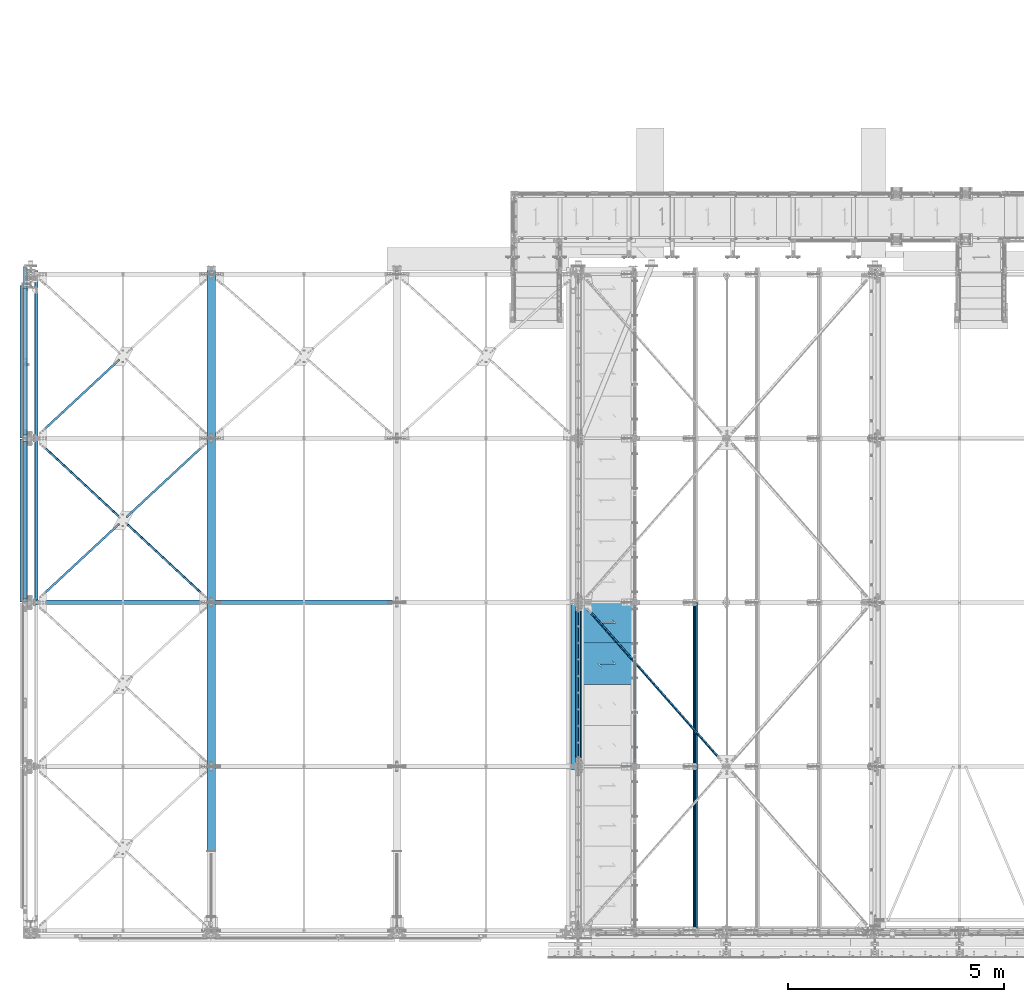
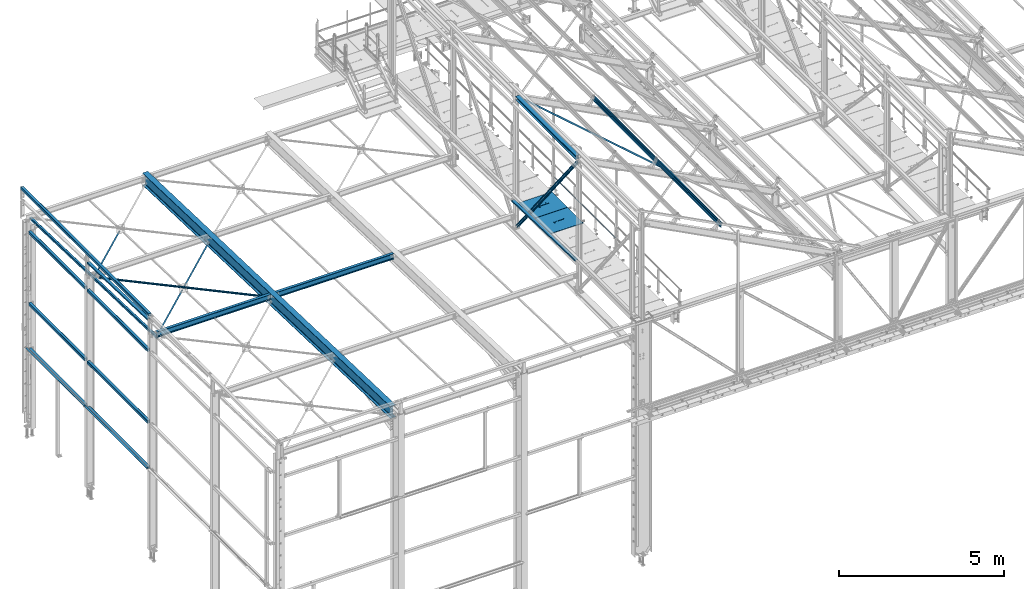
# One storey, part 43 of 496: 25 beams, 2 members, 25 elements without a shape of their own.
"""IFC2X3 building model written with IfcOpenShell, lengths in millimetres."""

from ifc_helpers import new_model, si_unit, frame, origin_with_axes, origin_2d_with_axis, place, context, subcontext, project, spatial, polyline, hollow_rectangle, hollow_circle, i_section, l_section, u_section, outline, extrude, boolean, clip, halfspace, material, type_object, element, aggregate, save


model = new_model("IFC2X3")

# Units and contexts
model_context = context("Model", 3, precision=1e-05, world=origin_with_axes())
body_context = subcontext(model_context, "Body", "Model", "MODEL_VIEW")
ifc_project = project(units=[si_unit("LENGTHUNIT", "METRE", prefix="MILLI"), si_unit("AREAUNIT", "SQUARE_METRE"), si_unit("VOLUMEUNIT", "CUBIC_METRE"), si_unit("MASSUNIT", "GRAM", prefix="KILO"), si_unit("TIMEUNIT", "SECOND"), si_unit("PLANEANGLEUNIT", "RADIAN"), si_unit("SOLIDANGLEUNIT", "STERADIAN"), si_unit("THERMODYNAMICTEMPERATUREUNIT", "DEGREE_CELSIUS"), si_unit("LUMINOUSINTENSITYUNIT", "LUMEN")], contexts=[model_context])

# Site, building, storey
site_placement = place(None, origin_with_axes())
site = spatial("IfcSite", under=ifc_project, at=site_placement, CompositionType="ELEMENT")
building_placement = place(site_placement, origin_with_axes())
building = spatial("IfcBuilding", under=site, at=building_placement, Name="Undefined", CompositionType="ELEMENT")
storey_placement = place(building_placement, origin_with_axes())
storey = spatial("IfcBuildingStorey", under=building, at=storey_placement, Name="Undefined", CompositionType="ELEMENT", Elevation=0.0)

# Assembly, beam
assembly_1_placement = place(storey_placement, origin_with_axes())
assembly_1 = element("IfcElementAssembly", 1, at=assembly_1_placement, inside=storey, AssemblyPlace="NOTDEFINED", PredefinedType="NOTDEFINED")
ifc_material_1 = material(Name="Undefined/S235-E24")
beam_type_1 = type_object("IfcBeamType", PredefinedType="NOTDEFINED")
beam_1_placement = place(assembly_1_placement, frame((2132.95804506702, 9498.08089601853, 7520.39497670018), z_axis=(0.680837487259443, -0.732073090297316, 0.0230066600093442), x_axis=(0.732434511694635, 0.680501526716288, -0.0213859349910859)))
beam_1 = element("IfcBeam", 2, at=beam_1_placement, type_object=beam_type_1, material=ifc_material_1, context=body_context, shape_type="Clipping", body=[
    clip(clip(extrude(l_section(Depth=50.0, Width=50.0, Thickness=5.0, FilletRadius=7.0, EdgeRadius=3.5, at=origin_2d_with_axis()), frame((2749.59772887695, -9.53958345955073e-15, 7.48261077608511e-14), z_axis=(-1.0, 0.0, 0.0), x_axis=(0.0, -1.0, 0.0)), (0.0, 0.0, 1.0), 2694.26), halfspace(frame((2629.60114437331, 24.9946777552568, 24.9964587527593), z_axis=(0.999999999999294, 3.87284877892096e-07, -1.12347404979193e-06), x_axis=(-1.44599998020567e-06, 0.0, -0.999999999998955)), False)), halfspace(frame((106.894615096866, 31.0043411251254, 25.0000010076456), z_axis=(1.0, 0.0, 0.0), x_axis=(0.0, 1.0, 0.0)), True)),
])
aggregate(assembly_1, [beam_1])

assembly_2_placement = place(storey_placement, origin_with_axes())
assembly_2 = element("IfcElementAssembly", 3, at=assembly_2_placement, inside=storey, AssemblyPlace="NOTDEFINED", PredefinedType="NOTDEFINED")
beam_2_placement = place(assembly_2_placement, frame((87.9574875420612, 11398.0808647091, 7460.68529693561), z_axis=(0.680837487259443, -0.732073090297316, 0.0230066600093442), x_axis=(0.732434511694635, 0.680501526716288, -0.0213859349910859)))
beam_2 = element("IfcBeam", 4, at=beam_2_placement, type_object=beam_type_1, material=ifc_material_1, context=body_context, shape_type="Clipping", body=[
    clip(clip(extrude(l_section(Depth=50.0, Width=50.0, Thickness=5.0, FilletRadius=7.0, EdgeRadius=3.5, at=origin_2d_with_axis()), frame((2736.71685239602, 9.09494701772928e-13, 1.12639368525833e-12), z_axis=(-1.0, 0.0, 0.0), x_axis=(0.0, -1.0, 0.0)), (0.0, 0.0, 1.0), 2736.72), halfspace(frame((162.463643514807, -24.9999731432417, 25.0000104208884), z_axis=(-1.0, 0.0, 0.0), x_axis=(0.0, 0.0, -1.0)), False)), halfspace(frame((2685.16386215438, 31.0042426600348, -24.9999999881802), z_axis=(-1.0, 0.0, 0.0), x_axis=(0.0, 1.0, 0.0)), True)),
])
aggregate(assembly_2, [beam_2])

assembly_3_placement = place(storey_placement, origin_with_axes())
assembly_3 = element("IfcElementAssembly", 5, at=assembly_3_placement, inside=storey, AssemblyPlace="NOTDEFINED", PredefinedType="NOTDEFINED")
beam_3_placement = place(assembly_3_placement, frame((4182.04254050841, 7599.8394379966, 7636.08110078026), z_axis=(-0.680837484653578, -0.732073079616414, 0.0230070769879449), x_axis=(-0.732434513155022, 0.680501525144028, -0.0213859350045245)))
beam_3 = element("IfcBeam", 6, at=beam_3_placement, type_object=beam_type_1, material=ifc_material_1, context=body_context, shape_type="Clipping", body=[
    clip(clip(extrude(l_section(Depth=50.0, Width=50.0, Thickness=5.0, FilletRadius=7.0, EdgeRadius=3.5, at=origin_2d_with_axis()), frame((5584.11699845502, 9.2886849947257e-13, 1.41670895678633e-13), z_axis=(-1.0, 0.0, 0.0), x_axis=(0.0, -1.0, 0.0)), (0.0, 0.0, 1.0), 5584.12), halfspace(frame((5421.65334739776, -24.9999835437211, -25.0000000106447), z_axis=(1.0, 0.0, 0.0), x_axis=(0.0, 0.0, 1.0)), False)), halfspace(frame((162.4631484794, 24.9999835444978, -24.9999999958345), z_axis=(-1.0, 0.0, 0.0), x_axis=(0.0, 0.0, 1.0)), False)),
])
aggregate(assembly_3, [beam_3])

assembly_4_placement = place(storey_placement, origin_with_axes())
assembly_4 = element("IfcElementAssembly", 7, at=assembly_4_placement, inside=storey, AssemblyPlace="NOTDEFINED", PredefinedType="NOTDEFINED")
beam_4_placement = place(assembly_4_placement, frame((56.8583181152871, 7569.18625596313, 7581.01491732312), z_axis=(0.680837487259443, -0.732073090297316, 0.0230066600093442), x_axis=(0.732434511694635, 0.680501526716288, -0.0213859349910859)))
beam_4 = element("IfcBeam", 8, at=beam_4_placement, type_object=beam_type_1, material=ifc_material_1, context=body_context, shape_type="Clipping", body=[
    clip(clip(extrude(l_section(Depth=50.0, Width=50.0, Thickness=5.0, FilletRadius=7.0, EdgeRadius=3.5, at=origin_2d_with_axis()), frame((2779.17762638619, -9.09494701772928e-13, -9.90549524077681e-13), z_axis=(-1.0, 0.0, 0.0), x_axis=(0.0, -1.0, 0.0)), (0.0, 0.0, 1.0), 2779.18), halfspace(frame((204.923128129719, -24.9999566922288, 25.0000208132915), z_axis=(-1.0, 0.0, 0.0), x_axis=(0.0, 0.0, -1.0)), False)), halfspace(frame((2727.6246361294, 31.004259119446, 25.0000000419741), z_axis=(1.0, 0.0, 0.0), x_axis=(0.0, 1.0, 0.0)), False)),
])
aggregate(assembly_4, [beam_4])

assembly_5_placement = place(storey_placement, origin_with_axes())
assembly_5 = element("IfcElementAssembly", 9, at=assembly_5_placement, inside=storey, AssemblyPlace="NOTDEFINED", PredefinedType="NOTDEFINED")
beam_type_2 = type_object("IfcBeamType", PredefinedType="NOTDEFINED")
beam_5_placement = place(assembly_5_placement, frame((16127.0203983395, 3797.88523671946, 10301.8376740946), z_axis=(0.46352885499701, 6.99999093634976e-09, 0.886081824994261), x_axis=(-0.624617921816656, 0.709285727791797, 0.326750987904095)))
beam_5 = element("IfcBeam", 10, at=beam_5_placement, type_object=beam_type_2, material=ifc_material_1, context=body_context, shape_type="Clipping", body=[
    clip(clip(extrude(l_section(Depth=60.0, Width=60.0, Thickness=6.0, FilletRadius=8.0, EdgeRadius=4.0, at=origin_2d_with_axis()), frame((5268.62291314195, -4.3870098496784e-13, -3.93044613040361e-12), z_axis=(-1.0, 0.0, 0.0), x_axis=(0.0, -1.0, 0.0)), (0.0, 0.0, 1.0), 5179.74), halfspace(frame((5188.72411935052, -29.999998939431, -29.999975693936), z_axis=(1.0, 0.0, 0.0), x_axis=(0.0, 0.0, 1.0)), False)), halfspace(frame((168.778197882101, 30.0000010975073, -29.9999492865718), z_axis=(-1.0, 0.0, 0.0), x_axis=(0.0, 0.0, 1.0)), False)),
])
aggregate(assembly_5, [beam_5])

assembly_6_placement = place(storey_placement, origin_with_axes())
assembly_6 = element("IfcElementAssembly", 11, at=assembly_6_placement, inside=storey, Name="LISSE", AssemblyPlace="NOTDEFINED", PredefinedType="NOTDEFINED")
beam_type_3 = type_object("IfcBeamType", PredefinedType="NOTDEFINED")
beam_6_placement = place(assembly_6_placement, frame((12563.5000000007, 3730.03454686984, 8413.05496432255), z_axis=(1.0, 0.0, 0.0), x_axis=(0.0, 0.999506445341009, -0.0314144190107172)))
beam_6 = element("IfcBeam", 12, at=beam_6_placement, type_object=beam_type_3, material=ifc_material_1, Name="LISSE", context=body_context, shape_type="SweptSolid", body=[
    extrude(u_section(Depth=100.0, FlangeWidth=50.0, WebThickness=4.0, FlangeThickness=4.0, at=origin_2d_with_axis()), frame((3864.8364307433, 0.0, 0.0), z_axis=(-1.0, 0.0, 0.0), x_axis=(0.0, -1.0, 0.0)), (0.0, 0.0, 1.0), 3864.84),
])
aggregate(assembly_6, [beam_6])

assembly_7_placement = place(storey_placement, origin_with_axes())
assembly_7 = element("IfcElementAssembly", 13, at=assembly_7_placement, inside=storey, Name="LISSE", AssemblyPlace="NOTDEFINED", PredefinedType="NOTDEFINED")
beam_7_placement = place(assembly_7_placement, frame((-129.99999999132, 7600.0, 8291.42237510326), z_axis=(1.0, 0.0, 0.0), x_axis=(0.0, 0.999506445341009, -0.0314144190107172)))
beam_7 = element("IfcBeam", 14, at=beam_7_placement, type_object=beam_type_3, material=ifc_material_1, Name="LISSE", context=body_context, shape_type="Clipping", body=[
    clip(clip(extrude(u_section(Depth=100.0, FlangeWidth=50.0, WebThickness=4.0, FlangeThickness=4.0, at=origin_2d_with_axis()), frame((3738.43154409699, 2.59405798515091e-14, 0.0), z_axis=(-1.0, 0.0, 0.0), x_axis=(0.0, -1.0, 0.0)), (0.0, 0.0, 1.0), 3674.99), halfspace(frame((3731.98221168591, 154.697322046104, 49.9999999913198), z_axis=(-0.999506472307554, -0.0314135610096736, 0.0), x_axis=(0.0, 0.0, 1.0)), True)), halfspace(frame((63.7935542847008, 39.4064997178375, 49.9999999913198), z_axis=(-0.999506472307554, -0.0314135610096736, 0.0), x_axis=(0.0, 0.0, 1.0)), False)),
])
aggregate(assembly_7, [beam_7])

assembly_8_placement = place(storey_placement, origin_with_axes())
assembly_8 = element("IfcElementAssembly", 15, at=assembly_8_placement, inside=storey, Name="LISSE", AssemblyPlace="NOTDEFINED", PredefinedType="NOTDEFINED")
beam_type_4 = type_object("IfcBeamType", PredefinedType="NOTDEFINED")
beam_8_placement = place(assembly_8_placement, frame((-129.999997908177, 11324.9999913189, 4500.00000044976), z_axis=(0.0, 0.0, 1.0), x_axis=(0.0, -1.0, 0.0)))
beam_8 = element("IfcBeam", 16, at=beam_8_placement, type_object=beam_type_4, material=ifc_material_1, Name="LISSE", context=body_context, shape_type="SweptSolid", body=[
    extrude(hollow_rectangle(XDim=100.0, YDim=100.0, WallThickness=4.0, InnerFilletRadius=4.0, OuterFilletRadius=8.0, at=origin_2d_with_axis()), frame((3650.0, 0.0, 0.0), z_axis=(-1.0, 0.0, 0.0), x_axis=(0.0, -1.0, 0.0)), (0.0, 0.0, 1.0), 3650.0),
])
aggregate(assembly_8, [beam_8])

assembly_9_placement = place(storey_placement, origin_with_axes())
assembly_9 = element("IfcElementAssembly", 17, at=assembly_9_placement, inside=storey, Name="LISSE", AssemblyPlace="NOTDEFINED", PredefinedType="NOTDEFINED")
beam_9_placement = place(assembly_9_placement, frame((-129.99999629765, 14880.0000059275, 4500.00000075562), z_axis=(0.0, 0.0, 1.0), x_axis=(0.0, -1.0, 0.0)))
beam_9 = element("IfcBeam", 18, at=beam_9_placement, type_object=beam_type_4, material=ifc_material_1, Name="LISSE", context=body_context, shape_type="SweptSolid", body=[
    extrude(hollow_rectangle(XDim=100.0, YDim=100.0, WallThickness=4.0, InnerFilletRadius=4.0, OuterFilletRadius=8.0, at=origin_2d_with_axis()), frame((3405.00001460707, 0.0, 0.0), z_axis=(-1.0, 0.0, 0.0), x_axis=(0.0, -1.0, 0.0)), (0.0, 0.0, 1.0), 3405.0),
])
aggregate(assembly_9, [beam_9])

assembly_10_placement = place(storey_placement, origin_with_axes())
assembly_10 = element("IfcElementAssembly", 19, at=assembly_10_placement, inside=storey, Name="LISSE", AssemblyPlace="NOTDEFINED", PredefinedType="NOTDEFINED")
beam_10_placement = place(assembly_10_placement, frame((-129.999997902595, 11324.9999991089, 7150.00000059073), z_axis=(0.0, 0.0, -1.0), x_axis=(0.0, -1.0, 0.0)))
beam_10 = element("IfcBeam", 20, at=beam_10_placement, type_object=beam_type_4, material=ifc_material_1, Name="LISSE", context=body_context, shape_type="SweptSolid", body=[
    extrude(hollow_rectangle(XDim=100.0, YDim=100.0, WallThickness=4.0, InnerFilletRadius=4.0, OuterFilletRadius=8.0, at=origin_2d_with_axis()), frame((3650.0, 0.0, 0.0), z_axis=(-1.0, 0.0, 0.0), x_axis=(0.0, -1.0, 0.0)), (0.0, 0.0, 1.0), 3650.0),
])
aggregate(assembly_10, [beam_10])

assembly_11_placement = place(storey_placement, origin_with_axes())
assembly_11 = element("IfcElementAssembly", 21, at=assembly_11_placement, inside=storey, Name="LISSE", AssemblyPlace="NOTDEFINED", PredefinedType="NOTDEFINED")
beam_11_placement = place(assembly_11_placement, frame((-129.999997908177, 11324.999999003, 2810.00000033498), z_axis=(0.0, 0.0, 1.0), x_axis=(0.0, -1.0, 0.0)))
beam_11 = element("IfcBeam", 22, at=beam_11_placement, type_object=beam_type_4, material=ifc_material_1, Name="LISSE", context=body_context, shape_type="SweptSolid", body=[
    extrude(hollow_rectangle(XDim=100.0, YDim=100.0, WallThickness=4.0, InnerFilletRadius=4.0, OuterFilletRadius=8.0, at=origin_2d_with_axis()), frame((3650.0, 0.0, 0.0), z_axis=(-1.0, 0.0, 0.0), x_axis=(0.0, -1.0, 0.0)), (0.0, 0.0, 1.0), 3650.0),
])

assembly_12_placement = place(storey_placement, origin_with_axes())
assembly_12 = element("IfcElementAssembly", 23, at=assembly_12_placement, inside=storey, Name="LISSE", AssemblyPlace="NOTDEFINED", PredefinedType="NOTDEFINED")
beam_12_placement = place(assembly_12_placement, frame((-129.999996303045, 14880.0000025082, 7149.99999273054), z_axis=(0.0, 0.0, -1.0), x_axis=(0.0, -1.0, 0.0)))
beam_12 = element("IfcBeam", 24, at=beam_12_placement, type_object=beam_type_4, material=ifc_material_1, Name="LISSE", context=body_context, shape_type="SweptSolid", body=[
    extrude(hollow_rectangle(XDim=100.0, YDim=100.0, WallThickness=4.0, InnerFilletRadius=4.0, OuterFilletRadius=8.0, at=origin_2d_with_axis()), frame((3405.00001460707, 0.0, 0.0), z_axis=(-1.0, 0.0, 0.0), x_axis=(0.0, -1.0, 0.0)), (0.0, 0.0, 1.0), 3405.0),
])
aggregate(assembly_12, [beam_12])

assembly_13_placement = place(storey_placement, origin_with_axes())
assembly_13 = element("IfcElementAssembly", 25, at=assembly_13_placement, inside=storey, Name="LISSE", AssemblyPlace="NOTDEFINED", PredefinedType="NOTDEFINED")
beam_13_placement = place(assembly_13_placement, frame((-129.99999629765, 14880.000002399, 2810.00000064084), z_axis=(0.0, 0.0, 1.0), x_axis=(0.0, -1.0, 0.0)))
beam_13 = element("IfcBeam", 26, at=beam_13_placement, type_object=beam_type_4, material=ifc_material_1, Name="LISSE", context=body_context, shape_type="SweptSolid", body=[
    extrude(hollow_rectangle(XDim=100.0, YDim=100.0, WallThickness=4.0, InnerFilletRadius=4.0, OuterFilletRadius=8.0, at=origin_2d_with_axis()), frame((3405.00001460707, 0.0, 0.0), z_axis=(-1.0, 0.0, 0.0), x_axis=(0.0, -1.0, 0.0)), (0.0, 0.0, 1.0), 3405.0),
])

assembly_14_placement = place(storey_placement, origin_with_axes())
assembly_14 = element("IfcElementAssembly", 27, at=assembly_14_placement, inside=storey, Name="LISSE", AssemblyPlace="NOTDEFINED", PredefinedType="NOTDEFINED")
beam_14_placement = place(assembly_14_placement, frame((-129.999999773106, 15359.9999999742, 8500.00000002758), z_axis=(0.0, 0.0, 1.0), x_axis=(0.0, -1.0, 0.0)))
beam_14 = element("IfcBeam", 28, at=beam_14_placement, type_object=beam_type_4, material=ifc_material_1, Name="LISSE", context=body_context, shape_type="SweptSolid", body=[
    extrude(hollow_rectangle(XDim=100.0, YDim=100.0, WallThickness=4.0, InnerFilletRadius=4.0, OuterFilletRadius=8.0, at=origin_2d_with_axis()), frame((7755.0, 0.0, 0.0), z_axis=(-1.0, 0.0, 0.0), x_axis=(0.0, -1.0, 0.0)), (0.0, 0.0, 1.0), 7755.0),
])
aggregate(assembly_14, [beam_14])

assembly_15_placement = place(storey_placement, origin_with_axes())
assembly_15 = element("IfcElementAssembly", 29, at=assembly_15_placement, inside=storey, AssemblyPlace="NOTDEFINED", PredefinedType="NOTDEFINED")
beam_type_5 = type_object("IfcBeamType", PredefinedType="NOTDEFINED")
beam_15_placement = place(assembly_15_placement, frame((13936.4998878003, 6644.99999523074, 8115.0), z_axis=(0.0, 0.0, 1.0), x_axis=(-1.0, 0.0, 0.0)))
beam_15 = element("IfcBeam", 30, at=beam_15_placement, type_object=beam_type_5, material=ifc_material_1, context=body_context, shape_type="CSG", body=[
    boolean("DIFFERENCE", extrude(outline(polyline([(0.0, 0.0), (1179.99169921875, 0.0), (1179.99169921875, 940.0), (-9.39995516091585e-07, 940.0), (0.0, 0.0)])), frame((0.0, 0.0, -15.0), z_axis=(0.0, 0.0, 1.0), x_axis=(1.0, 0.0, 0.0)), (0.0, 0.0, 1.0), 30.0), extrude(outline(polyline([(0.0, 0.0), (9.99999999997453, 6.91215973347425e-11), (10.0000000004329, 75.8578643791443), (282.842712400121, -196.984848017997), (282.842712400743, -96.9848480190813), (272.842712400776, -96.9848480191613), (272.842712400299, -172.842712398218), (0.0, 100.0), (0.0, 0.0)])), frame((724.286946489367, 535.710676888644, -17.5), z_axis=(0.0, 0.0, 1.0), x_axis=(-0.707106781186457, -0.707106781186639, 0.0)), (0.0, 0.0, 1.0), 35.0)),
])
aggregate(assembly_15, [beam_15])

assembly_16_placement = place(storey_placement, origin_with_axes())
assembly_16 = element("IfcElementAssembly", 31, at=assembly_16_placement, inside=storey, AssemblyPlace="NOTDEFINED", PredefinedType="NOTDEFINED")
beam_16_placement = place(assembly_16_placement, frame((13936.4998935003, 7595.0, 8115.0), z_axis=(0.0, 0.0, 1.0), x_axis=(-1.0, 0.0, 0.0)))
beam_16 = element("IfcBeam", 32, at=beam_16_placement, type_object=beam_type_5, material=ifc_material_1, context=body_context, shape_type="CSG", body=[
    boolean("DIFFERENCE", extrude(outline(polyline([(0.0, 0.0), (1179.99169921875, 0.0), (1179.99169921875, 940.0), (-9.39995516091585e-07, 940.0), (0.0, 0.0)])), frame((0.0, 0.0, -15.0), z_axis=(0.0, 0.0, 1.0), x_axis=(1.0, 0.0, 0.0)), (0.0, 0.0, 1.0), 30.0), extrude(outline(polyline([(0.0, 0.0), (9.99999999997453, 6.91215973347425e-11), (10.0000000004329, 75.8578643791443), (282.842712400121, -196.984848017997), (282.842712400743, -96.9848480190813), (272.842712400776, -96.9848480191613), (272.842712400299, -172.842712398218), (0.0, 100.0), (0.0, 0.0)])), frame((724.286946489367, 535.710676888644, -17.5), z_axis=(0.0, 0.0, 1.0), x_axis=(-0.707106781186457, -0.707106781186639, 0.0)), (0.0, 0.0, 1.0), 35.0)),
])
aggregate(assembly_16, [beam_16])

# Beam
beam_type_6 = type_object("IfcBeamType", PredefinedType="NOTDEFINED")
beam_17_placement = place(assembly_11_placement, frame((-215.000001390421, 11389.9999976485, 2824.99999058648), z_axis=(-1.0, 0.0, 0.0), x_axis=(0.0, -1.0, 0.0)))
beam_17 = element("IfcBeam", 33, at=beam_17_placement, type_object=beam_type_6, material=ifc_material_1, Name="LISSE", context=body_context, shape_type="SweptSolid", body=[
    extrude(l_section(Depth=70.0, Width=70.0, Thickness=7.0, FilletRadius=9.0, EdgeRadius=4.5, at=origin_2d_with_axis()), frame((3779.99999902119, 1.5633713573204e-21, 0.0), z_axis=(-1.0, 0.0, 0.0), x_axis=(0.0, -1.0, 0.0)), (0.0, 0.0, 1.0), 3780.0),
])

aggregate(assembly_11, [beam_17, beam_11])

beam_18_placement = place(assembly_13_placement, frame((-215.000001390421, 14940.00000213, 2824.99999998415), z_axis=(-1.0, 0.0, 0.0), x_axis=(0.0, -1.0, 0.0)))
beam_18 = element("IfcBeam", 34, at=beam_18_placement, type_object=beam_type_6, material=ifc_material_1, Name="LISSE", context=body_context, shape_type="CSG", body=[
    boolean("DIFFERENCE", extrude(l_section(Depth=70.0, Width=70.0, Thickness=7.0, FilletRadius=9.0, EdgeRadius=4.5, at=origin_2d_with_axis()), frame((3530.00000340667, 0.0, 0.0), z_axis=(-1.0, 0.0, 0.0), x_axis=(0.0, -1.0, 0.0)), (0.0, 0.0, 1.0), 3530.0), extrude(outline(polyline([(0.0, 0.0), (63.0, -1.16415321826935e-10), (62.9999999999636, 39.9999999998872), (-7.20213847671403e-07, 40.0), (0.0, 0.0)])), frame((109.996850696747, -35.0, -37.5), z_axis=(0.0, 0.0, 1.0), x_axis=(0.0, 1.0, 0.0)), (0.0, 0.0, 1.0), 75.0)),
])

aggregate(assembly_13, [beam_18, beam_13])

# Assembly, beam
assembly_17_placement = place(storey_placement, origin_with_axes())
assembly_17 = element("IfcElementAssembly", 35, at=assembly_17_placement, inside=storey, Name="MAIN COURANTE", AssemblyPlace="NOTDEFINED", PredefinedType="NOTDEFINED")
beam_type_7 = type_object("IfcBeamType", PredefinedType="NOTDEFINED")
beam_19_placement = place(assembly_17_placement, frame((13993.9998882445, 7545.000009441, 8673.80000207863), z_axis=(0.0, 0.0, 1.0), x_axis=(0.0, -1.0, 0.0)))
beam_19 = element("IfcBeam", 36, at=beam_19_placement, type_object=beam_type_7, material=ifc_material_1, Name="LISSE", context=body_context, shape_type="SweptSolid", body=[
    extrude(hollow_circle(Radius=13.44999981, WallThickness=2.0, at=origin_2d_with_axis()), frame((3690.00000000169, 3.69000323827281e-24, 0.0), z_axis=(-1.0, 0.0, 0.0), x_axis=(0.0, -1.0, 0.0)), (0.0, 0.0, 1.0), 3690.0),
])
aggregate(assembly_17, [beam_19])

assembly_18_placement = place(storey_placement, origin_with_axes())
assembly_18 = element("IfcElementAssembly", 37, at=assembly_18_placement, inside=storey, AssemblyPlace="NOTDEFINED", PredefinedType="NOTDEFINED")
ifc_material_2 = material(Name="Undefined/S275-E28")
beam_type_8 = type_object("IfcBeamType", Name="HEA140", PredefinedType="NOTDEFINED")
beam_20_placement = place(assembly_18_placement, frame((12683.5, 7525.0, 12103.5), z_axis=(0.0, 0.0, 1.0), x_axis=(0.0, -1.0, 0.0)))
beam_20 = element("IfcBeam", 38, at=beam_20_placement, type_object=beam_type_8, material=ifc_material_2, ObjectType="HEA140", context=body_context, shape_type="SweptSolid", body=[
    extrude(i_section(OverallWidth=140.0, OverallDepth=133.0, WebThickness=5.5, FlangeThickness=8.5, FilletRadius=12.0, at=origin_2d_with_axis()), frame((3650.0, 0.0, 0.0), z_axis=(-1.0, 0.0, 0.0), x_axis=(0.0, -1.0, 0.0)), (0.0, 0.0, 1.0), 3650.0),
])
aggregate(assembly_18, [beam_20])

assembly_19_placement = place(storey_placement, origin_with_axes())
assembly_19 = element("IfcElementAssembly", 39, at=assembly_19_placement, inside=storey, Name="SHED", AssemblyPlace="NOTDEFINED", PredefinedType="NOTDEFINED")
beam_type_9 = type_object("IfcBeamType", PredefinedType="NOTDEFINED")
beam_21_placement = place(assembly_19_placement, frame((15396.2855150303, -154.999920381521, 11079.0980095689), z_axis=(0.46352885499701, 6.99999093634976e-09, 0.886081824994261), x_axis=(0.0, 1.0, 0.0)))
beam_21 = element("IfcBeam", 40, at=beam_21_placement, type_object=beam_type_9, material=ifc_material_1, Name="SHED", context=body_context, shape_type="SweptSolid", body=[
    extrude(outline(polyline([(-27.9999999860338, 36.0000000101354), (-27.999999986052, 70.0000000101354), (28.0000000138389, 70.0000000101209), (28.0000000138425, 58.0000000101209), (26.5000000138534, 58.0000000101209), (26.5000000138352, 68.5000000101172), (-26.4999999860593, 68.5000000101354), (-26.4999999860338, 36.7000007730749), (-1.49999998607018, 15.6999998194005), (-1.49999998605563, -15.6999997991297), (-26.4999999859974, -36.7000007527895), (-26.4999999859829, -68.49999998985), (26.5000000139153, -68.4999999898646), (26.500000013908, -57.9999999898646), (28.0000000139116, -57.9999999898646), (28.0000000139153, -69.9999999898646), (-27.9999999859756, -69.99999998985), (-27.9999999859901, -35.99999998985), (-2.99999998605927, -14.9999999898646), (-2.9999999860629, 15.0000000101354), (-27.9999999860338, 36.0000000101354)])), frame((7750.00000000006, -3.63797880548905e-12, 0.0), z_axis=(-1.0, 0.0, 0.0), x_axis=(0.0, -1.0, 0.0)), (0.0, 0.0, 1.0), 7750.0),
])
aggregate(assembly_19, [beam_21])

# Assembly, member
assembly_20_placement = place(storey_placement, origin_with_axes())
assembly_20 = element("IfcElementAssembly", 41, at=assembly_20_placement, inside=storey, AssemblyPlace="NOTDEFINED", PredefinedType="NOTDEFINED")
member_type = type_object("IfcMemberType", Name="UPN80", PredefinedType="NOTDEFINED")
member_1_placement = place(assembly_20_placement, frame((12707.4999999937, 7599.99999999989, 7250.0), z_axis=(0.0, -0.783225663730114, -0.621737532785759), x_axis=(0.0, -0.621737529971512, 0.78322566596411)))
member_1 = element("IfcMember", 42, at=member_1_placement, type_object=member_type, material=ifc_material_2, ObjectType="UPN80", context=body_context, shape_type="Clipping", body=[
    clip(clip(extrude(u_section(Depth=80.0, FlangeWidth=45.0, WebThickness=6.0, FlangeThickness=8.0, FilletRadius=8.0, EdgeRadius=4.0, FlangeSlope=0.0798299857122373, at=origin_2d_with_axis()), frame((6070.59674052178, 0.0, 0.0), z_axis=(-1.0, 0.0, 0.0), x_axis=(0.0, -1.0, 0.0)), (0.0, 0.0, 1.0), 6029.29), halfspace(frame((5991.90387685635, 27.5000000297259, -40.0000004439507), z_axis=(-1.0, 0.0, 0.0), x_axis=(0.0, 1.0, 0.0)), True)), halfspace(frame((119.999999997919, 27.49999999375, -39.9999989691296), z_axis=(-1.0, 0.0, 0.0), x_axis=(0.0, 1.0, 0.0)), False)),
])
aggregate(assembly_20, [member_1])

assembly_21_placement = place(storey_placement, origin_with_axes())
assembly_21 = element("IfcElementAssembly", 43, at=assembly_21_placement, inside=storey, AssemblyPlace="NOTDEFINED", PredefinedType="NOTDEFINED")
member_2_placement = place(assembly_21_placement, frame((12652.4999999902, 3800.00000000027, 12037.0), z_axis=(0.0, -0.783225663730114, -0.621737532785759), x_axis=(0.0, 0.621737532785759, -0.783225663730114)))
member_2 = element("IfcMember", 44, at=member_2_placement, type_object=member_type, material=ifc_material_2, ObjectType="UPN80", context=body_context, shape_type="Clipping", body=[
    clip(clip(extrude(u_section(Depth=80.0, FlangeWidth=45.0, WebThickness=6.0, FlangeThickness=8.0, FilletRadius=8.0, EdgeRadius=4.0, FlangeSlope=0.0798299857122373, at=origin_2d_with_axis()), frame((6070.59674052178, 0.0, 0.0), z_axis=(-1.0, 0.0, 0.0), x_axis=(0.0, -1.0, 0.0)), (0.0, 0.0, 1.0), 6029.29), halfspace(frame((5991.90387685635, 27.5000000297259, -40.0000004439507), z_axis=(1.0, 0.0, 0.0), x_axis=(0.0, -1.0, 0.0)), False)), halfspace(frame((119.999999997919, 27.49999999375, -39.9999989691296), z_axis=(1.0, 0.0, 0.0), x_axis=(0.0, -1.0, 0.0)), True)),
])
aggregate(assembly_21, [member_2])

# Assembly, beam
assembly_22_placement = place(storey_placement, origin_with_axes())
assembly_22 = element("IfcElementAssembly", 45, at=assembly_22_placement, inside=storey, Name="TRAVERSE", AssemblyPlace="NOTDEFINED", PredefinedType="NOTDEFINED")
beam_type_10 = type_object("IfcBeamType", Name="IPE450", PredefinedType="NOTDEFINED")
beam_22_placement = place(assembly_22_placement, frame((4180.00000000071, -7.06742078496467, 7825.11102391607), z_axis=(0.0, -0.031410887010906, -0.999506556345274), x_axis=(0.0, 0.999506556345274, -0.0314108870109058)))
beam_22 = element("IfcBeam", 46, at=beam_22_placement, type_object=beam_type_10, material=ifc_material_2, Name="TRAVERSE", ObjectType="IPE450", context=body_context, shape_type="Clipping", body=[
    clip(clip(extrude(i_section(OverallWidth=190.0, OverallDepth=450.0, WebThickness=9.399999619, FlangeThickness=14.60000038, FilletRadius=21.0, at=origin_2d_with_axis()), frame((15397.5977849943, 0.0, 0.0), z_axis=(-1.0, 0.0, 0.0), x_axis=(0.0, -1.0, 0.0)), (0.0, 0.0, 1.0), 15397.6), halfspace(frame((15367.5829744977, -95.0, -224.999999999999), z_axis=(0.999506560367824, 0.0, -0.0314107590115582), x_axis=(0.0314107590115582, 0.0, 0.999506560367824)), False)), halfspace(frame((335.150577048107, 95.0, -225.471161384995), z_axis=(-0.999506560367824, 0.0, 0.0314107590115593), x_axis=(0.0314107590115582, 0.0, 0.999506560367824)), False)),
])
aggregate(assembly_22, [beam_22])

assembly_23_placement = place(storey_placement, origin_with_axes())
assembly_23 = element("IfcElementAssembly", 47, at=assembly_23_placement, inside=storey, AssemblyPlace="NOTDEFINED", PredefinedType="NOTDEFINED")
beam_type_11 = type_object("IfcBeamType", PredefinedType="NOTDEFINED")
beam_23_placement = place(assembly_23_placement, frame((130.000000000713, 7598.74356920001, 7571.08129582646), z_axis=(0.0, -0.031410887010906, -0.999506556345274), x_axis=(0.0, 0.999506556345274, -0.0314108870109058)))
beam_23 = element("IfcBeam", 48, at=beam_23_placement, type_object=beam_type_11, material=ifc_material_1, context=body_context, shape_type="Clipping", body=[
    clip(clip(extrude(hollow_rectangle(XDim=80.0, YDim=80.0, WallThickness=4.0, InnerFilletRadius=4.0, OuterFilletRadius=8.0, at=origin_2d_with_axis()), frame((7697.59272339855, 0.0, 0.0), z_axis=(-1.0, 0.0, 0.0), x_axis=(0.0, -1.0, 0.0)), (0.0, 0.0, 1.0), 7693.87), halfspace(frame((7694.85502608921, -130.000000000713, -6.31491058550273), z_axis=(0.999506560367824, 0.0, -0.0314107590115582), x_axis=(0.0, -1.0, 0.0)), False)), halfspace(frame((7.68193313050961, -130.000000000713, 45.2619199585406), z_axis=(-0.999506560367824, 0.0, 0.0314107590115593), x_axis=(0.0, -1.0, 0.0)), False)),
])
aggregate(assembly_23, [beam_23])

assembly_24_placement = place(storey_placement, origin_with_axes())
assembly_24 = element("IfcElementAssembly", 49, at=assembly_24_placement, inside=storey, AssemblyPlace="NOTDEFINED", PredefinedType="NOTDEFINED")
beam_type_12 = type_object("IfcBeamType", Name="IPE200", PredefinedType="NOTDEFINED")
beam_24_placement = place(assembly_24_placement, frame((4280.0, 7599.99999998577, 7711.11096504119), z_axis=(0.0, 0.031410887010906, 0.999506556345274), x_axis=(1.0, 0.0, 0.0)))
beam_24 = element("IfcBeam", 50, at=beam_24_placement, type_object=beam_type_12, material=ifc_material_2, ObjectType="IPE200", context=body_context, shape_type="SweptSolid", body=[
    extrude(i_section(OverallWidth=100.0, OverallDepth=200.0, WebThickness=5.599999905, FlangeThickness=8.5, FilletRadius=12.0, at=origin_2d_with_axis()), frame((4100.0, 0.0, 0.0), z_axis=(-1.0, 0.0, 0.0), x_axis=(0.0, -1.0, 0.0)), (0.0, 0.0, 1.0), 4100.0),
])
aggregate(assembly_24, [beam_24])

assembly_25_placement = place(storey_placement, origin_with_axes())
assembly_25 = element("IfcElementAssembly", 51, at=assembly_25_placement, inside=storey, AssemblyPlace="NOTDEFINED", PredefinedType="NOTDEFINED")
beam_25_placement = place(assembly_25_placement, frame((100.000000000018, 7599.99999998546, 7711.11096504116), z_axis=(0.0, 0.031410887010906, 0.999506556345274), x_axis=(1.0, 0.0, 0.0)))
beam_25 = element("IfcBeam", 52, at=beam_25_placement, type_object=beam_type_12, material=ifc_material_2, ObjectType="IPE200", context=body_context, shape_type="SweptSolid", body=[
    extrude(i_section(OverallWidth=100.0, OverallDepth=200.0, WebThickness=5.599999905, FlangeThickness=8.5, FilletRadius=12.0, at=origin_2d_with_axis()), frame((3980.00000000009, 0.0, 0.0), z_axis=(-1.0, 0.0, 0.0), x_axis=(0.0, -1.0, 0.0)), (0.0, 0.0, 1.0), 3980.0),
])
aggregate(assembly_25, [beam_25])

save(model, "model.ifc")
